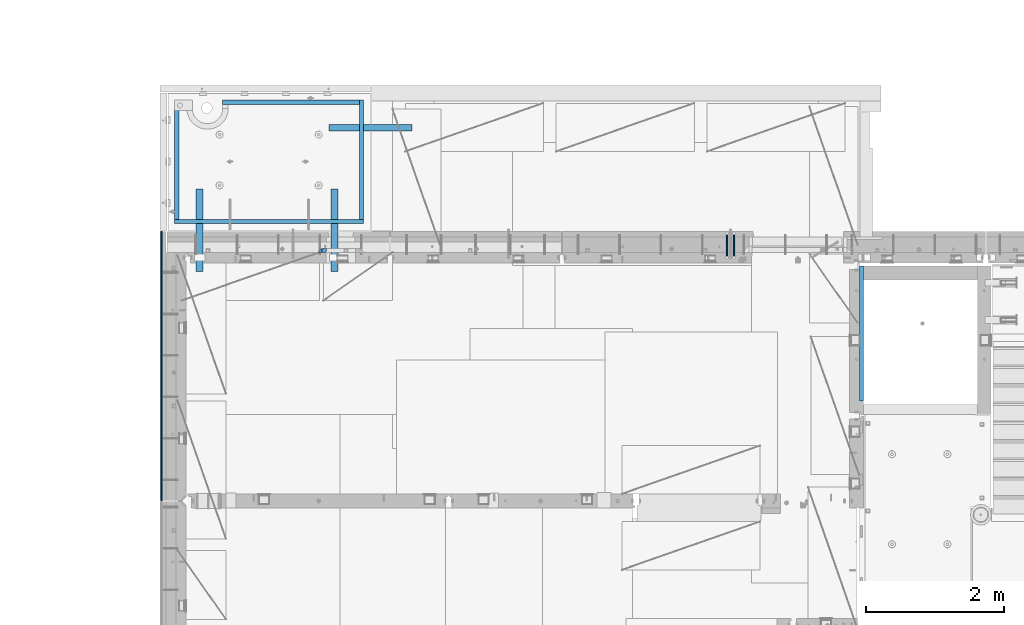
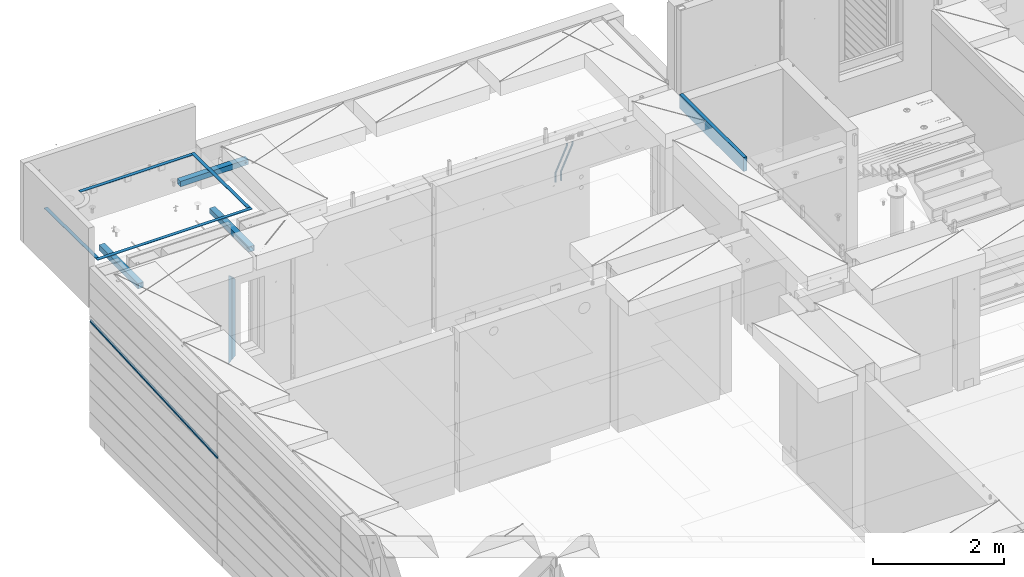
# One storey, part 102 of 325: 13 beams, 8 elements without a shape of their own.
"""IFC2X3 building model written with IfcOpenShell, lengths in millimetres."""

from ifc_helpers import new_model, si_unit, frame, origin_with_axes, place, context, subcontext, project, spatial, faceted_brep, material, type_object, element, aggregate, save


model = new_model("IFC2X3")

# Units and contexts
model_context = context("Model", 3, precision=1e-05, world=origin_with_axes())
body_context = subcontext(model_context, "Body", "Model", "MODEL_VIEW")
ifc_project = project(units=[si_unit("LENGTHUNIT", "METRE", prefix="MILLI"), si_unit("AREAUNIT", "SQUARE_METRE"), si_unit("VOLUMEUNIT", "CUBIC_METRE"), si_unit("MASSUNIT", "GRAM", prefix="KILO"), si_unit("TIMEUNIT", "SECOND"), si_unit("PLANEANGLEUNIT", "RADIAN"), si_unit("SOLIDANGLEUNIT", "STERADIAN"), si_unit("THERMODYNAMICTEMPERATUREUNIT", "DEGREE_CELSIUS"), si_unit("LUMINOUSINTENSITYUNIT", "LUMEN")], contexts=[model_context])

# Site, building, storey
site_placement = place(None, origin_with_axes())
site = spatial("IfcSite", under=ifc_project, at=site_placement, CompositionType="ELEMENT")
building_placement = place(site_placement, origin_with_axes())
building = spatial("IfcBuilding", under=site, at=building_placement, CompositionType="ELEMENT")
storey_placement = place(building_placement, origin_with_axes())
storey = spatial("IfcBuildingStorey", under=building, at=storey_placement, Name="1", CompositionType="ELEMENT", Elevation=0.0)

# Assembly, beam
assembly_1_placement = place(storey_placement, origin_with_axes())
assembly_1 = element("IfcElementAssembly", 1, at=assembly_1_placement, inside=storey, AssemblyPlace="NOTDEFINED", PredefinedType="REINFORCEMENT_UNIT")
ifc_material_1 = material(Name="CONCRETE/C25/30")
beam_type_1 = type_object("IfcBeamType", Name="260X60", PredefinedType="NOTDEFINED")
beam_1_placement = place(assembly_1_placement, frame((17779.9999105288, 18424.9992663657, 84600.0), z_axis=(0.0, 0.0, 1.0), x_axis=(0.0, 1.0, 0.0)))
beam_1 = element("IfcBeam", 2, at=beam_1_placement, type_object=beam_type_1, material=ifc_material_1, ObjectType="260X60", context=body_context, shape_type="Brep", body=[
    faceted_brep([(0.0, 30.0, -130.0), (0.0, 30.0, 130.0), (1954.9989445891, 30.0, 130.0), (1954.9989445891, 30.0, -130.0), (0.0, -30.0, 130.0), (1954.9989445891, -30.0, 130.0), (0.0, -30.0, -130.0), (1954.9989445891, -30.0, -130.0)], [[[0, 1, 2, 3]], [[1, 4, 5, 2]], [[4, 6, 7, 5]], [[6, 0, 3, 7]], [[5, 7, 3, 2]], [[6, 4, 1, 0]]]),
])
aggregate(assembly_1, [beam_1])

assembly_2_placement = place(storey_placement, origin_with_axes())
assembly_2 = element("IfcElementAssembly", 3, at=assembly_2_placement, inside=storey, AssemblyPlace="NOTDEFINED", PredefinedType="REINFORCEMENT_UNIT")
ifc_material_2 = material(Name="TIMBER/T24")
beam_type_2 = type_object("IfcBeamType", PredefinedType="NOTDEFINED")
beam_2_placement = place(assembly_2_placement, frame((7642.5, 20883.779945659, 83740.0714198882), z_axis=(1.0, 0.0, 0.0), x_axis=(0.0, -0.998808676266891, -0.0487978300130376)))
beam_2 = element("IfcBeam", 4, at=beam_2_placement, type_object=beam_type_2, material=ifc_material_2, context=body_context, shape_type="Brep", body=[
    faceted_brep([(-6.20211649220437e-05, -25.1793446455267, -0.208622932433173), (-1.45519152283669e-11, -3.63797880709171e-12, -12.5), (3904.70170998569, -1.35032916092314, -12.5), (3904.70170998569, -25.0000000000146, -0.955337660966507), (0.0, 25.0, -12.5), (0.0, 25.0, 12.5), (3904.70170998569, 25.0, 12.5), (3904.70170998569, 25.0, -12.5), (0.0, -25.0, 12.5), (3904.70170998569, -25.0000000000146, 12.5)], [[[0, 1, 2, 3]], [[4, 5, 6, 7]], [[5, 8, 9, 6]], [[9, 8, 0, 3]], [[7, 6, 9, 3, 2]], [[4, 7, 2, 1]], [[8, 5, 4, 1, 0]]]),
])
aggregate(assembly_2, [beam_2])

# Assemblies, beams
assembly_3_placement = place(storey_placement, origin_with_axes())
assembly_3 = element("IfcElementAssembly", 5, at=assembly_3_placement, inside=storey, AssemblyPlace="NOTDEFINED", PredefinedType="REINFORCEMENT_UNIT")
assembly_4_placement = place(assembly_3_placement, origin_with_axes())
assembly_4 = element("IfcElementAssembly", 6, at=assembly_4_placement, AssemblyPlace="NOTDEFINED", PredefinedType="NOTDEFINED")
ifc_material_3 = material(Name="Undefined/350")
beam_type_3 = type_object("IfcBeamType", Name="100X100X5", PredefinedType="NOTDEFINED")
beam_3_placement = place(assembly_4_placement, frame((10069.9865573969, 22385.0401432011, 84555.0), z_axis=(0.0, 0.0, 1.0), x_axis=(0.999999999752625, -2.22429999942101e-05, 0.0)))
beam_3 = element("IfcBeam", 7, at=beam_3_placement, type_object=beam_type_3, material=ifc_material_3, ObjectType="100X100X5", context=body_context, shape_type="Brep", body=[
    faceted_brep([(1156.2510802317, 44.9999999999982, 10.8253175473074), (1156.25107855315, 50.0256005946221, 10.8253175473074), (1160.82639610046, 50.0256021227788, 6.25), (1160.82639777901, 44.9999999999982, 6.25), (1150.00108023171, 44.9999999999982, 12.5), (1150.00107855316, 50.0255985071226, 12.5), (1143.75108023171, 44.9999999999982, 10.8253175473074), (1143.75107855316, 50.0255964196231, 10.8253175473074), (1139.1757626844, 44.9999999999982, 6.25), (1139.17576100585, 50.0255948914664, 6.25), (1137.5010802317, 44.9999999999982, 0.0), (1137.50107855316, 50.0255943321226, 0.0), (1139.1757626844, 44.9999999999982, -6.25), (1139.17576100585, 50.0255948914664, -6.25), (1143.75108023171, 44.9999999999982, -10.8253175473074), (1143.75107855316, 50.0255964196231, -10.8253175473074), (1150.00108023171, 44.9999999999982, -12.5), (1150.00107855316, 50.0255985071226, -12.5), (1156.2510802317, 44.9999999999982, -10.8253175473074), (1156.25107855315, 50.0256005946221, -10.8253175473074), (1160.82639777901, 44.9999999999982, -6.25), (1160.82639610046, 50.0256021227788, -6.25), (1162.50108023171, 44.9999999999982, 0.0), (1162.50107855316, 50.0256026821226, 0.0), (1156.25111195316, -49.9743994042774, 10.8253175473074), (1156.25111029171, -44.9999999999991, 10.8253175473074), (1160.82642783901, -44.9999999999991, 6.25), (1160.82642950046, -49.9743978761207, 6.25), (1150.00111195316, -49.9744014917787, 12.5), (1150.00111029171, -44.9999999999991, 12.5), (1143.75111195316, -49.9744035792783, 10.8253175473074), (1143.75111029171, -44.9999999999991, 10.8253175473074), (1139.17579440585, -49.9744051074349, 6.25), (1139.1757927444, -44.9999999999991, 6.25), (1137.50111195316, -49.9744056667778, 0.0), (1137.50111029171, -44.9999999999991, 0.0), (1139.17579440585, -49.9744051074349, -6.25), (1139.1757927444, -44.9999999999991, -6.25), (1143.75111195316, -49.9744035792783, -10.8253175473074), (1143.75111029171, -44.9999999999991, -10.8253175473074), (1150.00111195316, -49.9744014917787, -12.5), (1150.00111029171, -44.9999999999991, -12.5), (1156.25111195316, -49.9743994042774, -10.8253175473074), (1156.25111029171, -44.9999999999991, -10.8253175473074), (1160.82642950046, -49.9743978761207, -6.25), (1160.82642783901, -44.9999999999991, -6.25), (1162.50111195316, -49.9743973167779, 0.0), (1162.50111029171, -44.9999999999991, 0.0), (1.81898940354586e-12, -50.0000000000009, -50.0), (1.81898940354586e-12, 49.9999999999991, -50.0), (1200.00449189278, 49.9999999999982, -50.0), (1200.00449189278, -50.0000000000009, -50.0), (1.81898940354586e-12, 49.9999999999991, 50.0), (1.81898940354586e-12, -50.0000000000009, 50.0), (1200.00449189278, -50.0000000000009, 50.0), (1200.00449189278, 49.9999999999982, 50.0), (0.0, 44.9999999999991, 45.0), (1.81898940354586e-12, -45.0000000000009, 45.0), (1.81898940354586e-12, -45.0000000000009, -45.0), (0.0, 44.9999999999991, -45.0), (1200.00449189278, 44.9999999999982, -45.0), (1200.00449189278, 44.9999999999982, 45.0), (1200.00449189278, -45.0000000000009, 45.0), (1200.00449189278, -45.0000000000009, -45.0)], [[[0, 1, 2, 3]], [[4, 5, 1, 0]], [[6, 7, 5, 4]], [[8, 9, 7, 6]], [[10, 11, 9, 8]], [[12, 13, 11, 10]], [[14, 15, 13, 12]], [[16, 17, 15, 14]], [[18, 19, 17, 16]], [[20, 21, 19, 18]], [[22, 23, 21, 20]], [[3, 2, 23, 22]], [[24, 25, 26, 27]], [[28, 29, 25, 24]], [[30, 31, 29, 28]], [[32, 33, 31, 30]], [[34, 35, 33, 32]], [[36, 37, 35, 34]], [[38, 39, 37, 36]], [[40, 41, 39, 38]], [[42, 43, 41, 40]], [[44, 45, 43, 42]], [[46, 47, 45, 44]], [[27, 26, 47, 46]], [[48, 49, 50, 51]], [[52, 53, 54, 55]], [[49, 52, 55, 50], [1, 5, 7, 9, 11, 13, 15, 17, 19, 21, 23, 2]], [[48, 53, 52, 49], [56, 57, 58, 59]], [[56, 59, 60, 61], [18, 16, 14, 12, 10, 8, 6, 4, 0, 3, 22, 20]], [[57, 56, 61, 62]], [[58, 57, 62, 63], [25, 29, 31, 33, 35, 37, 39, 41, 43, 45, 47, 26]], [[59, 58, 63, 60]], [[54, 51, 50, 55], [62, 61, 60, 63]], [[53, 48, 51, 54], [42, 40, 38, 36, 34, 32, 30, 28, 24, 27, 46, 44]]]),
])
aggregate(assembly_4, [beam_3])
assembly_5_placement = place(assembly_3_placement, origin_with_axes())
assembly_5 = element("IfcElementAssembly", 8, at=assembly_5_placement, AssemblyPlace="NOTDEFINED", PredefinedType="NOTDEFINED")
beam_4_placement = place(assembly_5_placement, frame((10150.0001432011, 21500.0034426031, 84555.0), z_axis=(0.0, 0.0, 1.0), x_axis=(-2.2242999997242e-05, -0.999999999752625, 0.0)))
beam_4 = element("IfcBeam", 9, at=beam_4_placement, type_object=beam_type_3, material=ifc_material_3, ObjectType="100X100X5", context=body_context, shape_type="Brep", body=[
    faceted_brep([(1143.75108023171, 44.9999999999982, -10.8253175473074), (1143.75107855316, 50.0255964196231, -10.8253175473074), (1139.17576100585, 50.0255948914664, -6.25), (1139.1757626844, 44.9999999999982, -6.25), (1150.00108023171, 44.9999999999982, -12.5), (1150.00107855316, 50.0255985071226, -12.5), (1156.2510802317, 44.9999999999982, -10.8253175473074), (1156.25107855315, 50.0256005946221, -10.8253175473074), (1160.82639777901, 44.9999999999982, -6.25), (1160.82639610046, 50.0256021227788, -6.25), (1162.50108023171, 44.9999999999982, 0.0), (1162.50107855316, 50.0256026821226, 0.0), (1160.82639777901, 44.9999999999982, 6.25), (1160.82639610046, 50.0256021227788, 6.25), (1156.2510802317, 44.9999999999982, 10.8253175473074), (1156.25107855315, 50.0256005946221, 10.8253175473074), (1150.00108023171, 44.9999999999982, 12.5), (1150.00107855316, 50.0255985071226, 12.5), (1143.75108023171, 44.9999999999982, 10.8253175473074), (1143.75107855316, 50.0255964196231, 10.8253175473074), (1139.1757626844, 44.9999999999982, 6.25), (1139.17576100585, 50.0255948914664, 6.25), (1137.5010802317, 44.9999999999982, 0.0), (1137.50107855316, 50.0255943321226, 0.0), (1143.75111195316, -49.9744035792783, -10.8253175473074), (1143.75111029171, -44.9999999999991, -10.8253175473074), (1139.1757927444, -44.9999999999991, -6.25), (1139.17579440585, -49.9744051074349, -6.25), (1150.00111195316, -49.9744014917787, -12.5), (1150.00111029171, -44.9999999999991, -12.5), (1156.25111195316, -49.9743994042774, -10.8253175473074), (1156.25111029171, -44.9999999999991, -10.8253175473074), (1160.82642950046, -49.9743978761207, -6.25), (1160.82642783901, -44.9999999999991, -6.25), (1162.50111195316, -49.9743973167779, 0.0), (1162.50111029171, -44.9999999999991, 0.0), (1160.82642950046, -49.9743978761207, 6.25), (1160.82642783901, -44.9999999999991, 6.25), (1156.25111195316, -49.9743994042774, 10.8253175473074), (1156.25111029171, -44.9999999999991, 10.8253175473074), (1150.00111195316, -49.9744014917787, 12.5), (1150.00111029171, -44.9999999999991, 12.5), (1143.75111195316, -49.9744035792783, 10.8253175473074), (1143.75111029171, -44.9999999999991, 10.8253175473074), (1139.17579440585, -49.9744051074349, 6.25), (1139.1757927444, -44.9999999999991, 6.25), (1137.50111195316, -49.9744056667778, 0.0), (1137.50111029171, -44.9999999999991, 0.0), (1.81898940354586e-12, -50.0000000000009, -50.0), (1.81898940354586e-12, 49.9999999999991, -50.0), (1200.00449189278, 49.9999999999982, -50.0), (1200.00449189278, -50.0000000000009, -50.0), (1.81898940354586e-12, 49.9999999999991, 50.0), (1.81898940354586e-12, -50.0000000000009, 50.0), (1200.00449189278, -50.0000000000009, 50.0), (1200.00449189278, 49.9999999999982, 50.0), (0.0, 44.9999999999991, 45.0), (1.81898940354586e-12, -45.0000000000009, 45.0), (1.81898940354586e-12, -45.0000000000009, -45.0), (0.0, 44.9999999999991, -45.0), (1200.00449189278, 44.9999999999982, -45.0), (1200.00449189278, 44.9999999999982, 45.0), (1200.00449189278, -45.0000000000009, 45.0), (1200.00449189278, -45.0000000000009, -45.0)], [[[0, 1, 2, 3]], [[4, 5, 1, 0]], [[6, 7, 5, 4]], [[8, 9, 7, 6]], [[10, 11, 9, 8]], [[12, 13, 11, 10]], [[14, 15, 13, 12]], [[16, 17, 15, 14]], [[18, 19, 17, 16]], [[20, 21, 19, 18]], [[22, 23, 21, 20]], [[3, 2, 23, 22]], [[24, 25, 26, 27]], [[28, 29, 25, 24]], [[30, 31, 29, 28]], [[32, 33, 31, 30]], [[34, 35, 33, 32]], [[36, 37, 35, 34]], [[38, 39, 37, 36]], [[40, 41, 39, 38]], [[42, 43, 41, 40]], [[44, 45, 43, 42]], [[46, 47, 45, 44]], [[27, 26, 47, 46]], [[48, 49, 50, 51]], [[52, 53, 54, 55]], [[49, 52, 55, 50], [15, 17, 19, 21, 23, 2, 1, 5, 7, 9, 11, 13]], [[48, 53, 52, 49], [56, 57, 58, 59]], [[56, 59, 60, 61], [6, 4, 0, 3, 22, 20, 18, 16, 14, 12, 10, 8]], [[57, 56, 61, 62]], [[58, 57, 62, 63], [39, 41, 43, 45, 47, 26, 25, 29, 31, 33, 35, 37]], [[59, 58, 63, 60]], [[54, 51, 50, 55], [62, 61, 60, 63]], [[53, 48, 51, 54], [30, 28, 24, 27, 46, 44, 42, 40, 38, 36, 34, 32]]]),
])
aggregate(assembly_5, [beam_4])
assembly_6_placement = place(assembly_3_placement, origin_with_axes())
assembly_6 = element("IfcElementAssembly", 10, at=assembly_6_placement, AssemblyPlace="NOTDEFINED", PredefinedType="NOTDEFINED")
beam_5_placement = place(assembly_6_placement, frame((8195.00014320107, 21500.0034426031, 84555.0), z_axis=(0.0, 0.0, 1.0), x_axis=(-2.2242999997242e-05, -0.999999999752625, 0.0)))
beam_5 = element("IfcBeam", 11, at=beam_5_placement, type_object=beam_type_3, material=ifc_material_3, ObjectType="100X100X5", context=body_context, shape_type="Brep", body=[
    faceted_brep([(1143.75108023171, 44.9999999999982, -10.8253175473074), (1143.75107855316, 50.0255964196231, -10.8253175473074), (1139.17576100585, 50.0255948914664, -6.25), (1139.1757626844, 44.9999999999982, -6.25), (1150.00108023171, 44.9999999999982, -12.5), (1150.00107855316, 50.0255985071226, -12.5), (1156.2510802317, 44.9999999999982, -10.8253175473074), (1156.25107855315, 50.0256005946221, -10.8253175473074), (1160.82639777901, 44.9999999999982, -6.25), (1160.82639610046, 50.0256021227788, -6.25), (1162.50108023171, 44.9999999999982, 0.0), (1162.50107855316, 50.0256026821226, 0.0), (1160.82639777901, 44.9999999999982, 6.25), (1160.82639610046, 50.0256021227788, 6.25), (1156.2510802317, 44.9999999999982, 10.8253175473074), (1156.25107855315, 50.0256005946221, 10.8253175473074), (1150.00108023171, 44.9999999999982, 12.5), (1150.00107855316, 50.0255985071226, 12.5), (1143.75108023171, 44.9999999999982, 10.8253175473074), (1143.75107855316, 50.0255964196231, 10.8253175473074), (1139.1757626844, 44.9999999999982, 6.25), (1139.17576100585, 50.0255948914664, 6.25), (1137.5010802317, 44.9999999999982, 0.0), (1137.50107855316, 50.0255943321226, 0.0), (1143.75111195316, -49.9744035792783, -10.8253175473074), (1143.75111029171, -44.9999999999991, -10.8253175473074), (1139.1757927444, -44.9999999999991, -6.25), (1139.17579440585, -49.9744051074349, -6.25), (1150.00111195316, -49.9744014917787, -12.5), (1150.00111029171, -44.9999999999991, -12.5), (1156.25111195316, -49.9743994042774, -10.8253175473074), (1156.25111029171, -44.9999999999991, -10.8253175473074), (1160.82642950046, -49.9743978761207, -6.25), (1160.82642783901, -44.9999999999991, -6.25), (1162.50111195316, -49.9743973167779, 0.0), (1162.50111029171, -44.9999999999991, 0.0), (1160.82642950046, -49.9743978761207, 6.25), (1160.82642783901, -44.9999999999991, 6.25), (1156.25111195316, -49.9743994042774, 10.8253175473074), (1156.25111029171, -44.9999999999991, 10.8253175473074), (1150.00111195316, -49.9744014917787, 12.5), (1150.00111029171, -44.9999999999991, 12.5), (1143.75111195316, -49.9744035792783, 10.8253175473074), (1143.75111029171, -44.9999999999991, 10.8253175473074), (1139.17579440585, -49.9744051074349, 6.25), (1139.1757927444, -44.9999999999991, 6.25), (1137.50111195316, -49.9744056667778, 0.0), (1137.50111029171, -44.9999999999991, 0.0), (1.81898940354586e-12, -50.0000000000009, -50.0), (1.81898940354586e-12, 49.9999999999991, -50.0), (1200.00449189278, 49.9999999999982, -50.0), (1200.00449189278, -50.0000000000009, -50.0), (1.81898940354586e-12, 49.9999999999991, 50.0), (1.81898940354586e-12, -50.0000000000009, 50.0), (1200.00449189278, -50.0000000000009, 50.0), (1200.00449189278, 49.9999999999982, 50.0), (0.0, 44.9999999999991, 45.0), (1.81898940354586e-12, -45.0000000000009, 45.0), (1.81898940354586e-12, -45.0000000000009, -45.0), (0.0, 44.9999999999991, -45.0), (1200.00449189278, 44.9999999999982, -45.0), (1200.00449189278, 44.9999999999982, 45.0), (1200.00449189278, -45.0000000000009, 45.0), (1200.00449189278, -45.0000000000009, -45.0)], [[[0, 1, 2, 3]], [[4, 5, 1, 0]], [[6, 7, 5, 4]], [[8, 9, 7, 6]], [[10, 11, 9, 8]], [[12, 13, 11, 10]], [[14, 15, 13, 12]], [[16, 17, 15, 14]], [[18, 19, 17, 16]], [[20, 21, 19, 18]], [[22, 23, 21, 20]], [[3, 2, 23, 22]], [[24, 25, 26, 27]], [[28, 29, 25, 24]], [[30, 31, 29, 28]], [[32, 33, 31, 30]], [[34, 35, 33, 32]], [[36, 37, 35, 34]], [[38, 39, 37, 36]], [[40, 41, 39, 38]], [[42, 43, 41, 40]], [[44, 45, 43, 42]], [[46, 47, 45, 44]], [[27, 26, 47, 46]], [[48, 49, 50, 51]], [[52, 53, 54, 55]], [[49, 52, 55, 50], [15, 17, 19, 21, 23, 2, 1, 5, 7, 9, 11, 13]], [[48, 53, 52, 49], [56, 57, 58, 59]], [[56, 59, 60, 61], [6, 4, 0, 3, 22, 20, 18, 16, 14, 12, 10, 8]], [[57, 56, 61, 62]], [[58, 57, 62, 63], [39, 41, 43, 45, 47, 26, 25, 29, 31, 33, 35, 37]], [[59, 58, 63, 60]], [[54, 51, 50, 55], [62, 61, 60, 63]], [[53, 48, 51, 54], [30, 28, 24, 27, 46, 44, 42, 40, 38, 36, 34, 32]]]),
])
aggregate(assembly_6, [beam_5])
ifc_material_4 = material(Name="CONCRETE/Concrete_Undefined")
beam_type_4 = type_object("IfcBeamType", PredefinedType="NOTDEFINED")
beam_6_placement = place(assembly_3_placement, frame((8529.99466999203, 22755.2837502302, 84702.830444231), z_axis=(-8.94119999996021e-05, 2.00000067707701e-09, 0.999999996002747), x_axis=(0.999999995749149, -2.25209999937896e-05, 8.94119999812374e-05)))
beam_6 = element("IfcBeam", 12, at=beam_6_placement, type_object=beam_type_4, material=ifc_material_4, context=body_context, shape_type="Brep", body=[
    faceted_brep([(2.5465851649642e-11, 29.9999999999982, -4.99999999998545), (-2.91038304567337e-11, 29.9999999999982, 5.0), (1980.00575712919, 30.0, 5.0), (1980.00575712919, 30.0, -5.0), (-2.5465851649642e-11, -30.0000000000018, 5.0), (1980.00575712919, -30.0, 5.0), (2.72848410531878e-11, -30.0000000000018, -4.99999999998545), (1980.00575712919, -30.0, -5.00000000001455)], [[[0, 1, 2, 3]], [[1, 4, 5, 2]], [[4, 6, 7, 5]], [[6, 0, 3, 7]], [[5, 7, 3, 2]], [[6, 4, 1, 0]]]),
])
beam_7_placement = place(assembly_3_placement, frame((10540.0586106742, 21059.9845873458, 84723.6637899649), z_axis=(-4.06999999693443e-07, 0.0121707750045615, 0.999925933374879), x_axis=(-3.34759999933477e-05, 0.999925932814682, -0.0121707749977451)))
beam_7 = element("IfcBeam", 13, at=beam_7_placement, type_object=beam_type_4, material=ifc_material_4, context=body_context, shape_type="Brep", body=[
    faceted_brep([(2.5465851649642e-11, 29.9999999999982, -4.99999999998545), (-2.91038304567337e-11, 29.9999999999982, 5.0), (1725.44357525616, 30.0000000000036, 5.00000000001455), (1725.4435752563, 30.0, -4.9999999999709), (-2.5465851649642e-11, -30.0000000000018, 5.0), (1725.44357525616, -29.9999999999964, 5.0000000000291), (2.72848410531878e-11, -30.0000000000018, -4.99999999998545), (1725.4435752563, -30.0, -4.99999999998545)], [[[0, 1, 2, 3]], [[1, 4, 5, 2]], [[4, 6, 7, 5]], [[6, 0, 3, 7]], [[5, 7, 3, 2]], [[6, 4, 1, 0]]]),
])
beam_8_placement = place(assembly_3_placement, frame((7864.99860986461, 21059.9382586606, 84723.2791563128), z_axis=(9.00000032044727e-09, 0.0117810320027604, 0.999930601234381), x_axis=(7.88999999912068e-07, 0.999930601234069, -0.011781032002762)))
beam_8 = element("IfcBeam", 14, at=beam_8_placement, type_object=beam_type_4, material=ifc_material_4, context=body_context, shape_type="Brep", body=[
    faceted_brep([(2.5465851649642e-11, 29.9999999999982, -4.99999999998545), (-2.91038304567337e-11, 29.9999999999982, 5.0), (1580.11368192099, 30.0000000000018, 5.0), (1580.11368192098, 30.0000000000009, -5.00000000001455), (-2.5465851649642e-11, -30.0000000000018, 5.0), (1580.11368192098, -29.9999999999991, 5.0), (2.72848410531878e-11, -30.0000000000018, -4.99999999998545), (1580.11368192098, -30.0, -5.0)], [[[0, 1, 2, 3]], [[1, 4, 5, 2]], [[4, 6, 7, 5]], [[6, 0, 3, 7]], [[5, 7, 3, 2]], [[6, 4, 1, 0]]]),
])
beam_9_placement = place(assembly_3_placement, frame((7834.99819277187, 21029.998155674, 84724.2788443216), z_axis=(-0.000140627000015522, 4.00000135459113e-09, 0.999999990112023), x_axis=(0.999999989763253, -2.64109999939869e-05, 0.000140626999967189)))
beam_9 = element("IfcBeam", 15, at=beam_9_placement, type_object=beam_type_4, material=ifc_material_4, context=body_context, shape_type="Brep", body=[
    faceted_brep([(2.5465851649642e-11, 29.9999999999982, -4.99999999998545), (-2.91038304567337e-11, 29.9999999999982, 5.0), (2735.00002544224, 30.0, 5.0), (2735.00002544224, 30.0, -5.0), (-2.5465851649642e-11, -30.0000000000018, 5.0), (2735.00002544224, -29.9999999999964, 5.0), (2.72848410531878e-11, -30.0000000000018, -4.99999999998545), (2735.00002544224, -29.9999999999964, -5.0)], [[[0, 1, 2, 3]], [[1, 4, 5, 2]], [[4, 6, 7, 5]], [[6, 0, 3, 7]], [[5, 7, 3, 2]], [[6, 4, 1, 0]]]),
])
aggregate(assembly_3, [assembly_4, assembly_5, assembly_6, beam_6, beam_7, beam_8, beam_9])

# Assembly, beams
assembly_7_placement = place(storey_placement, origin_with_axes())
assembly_7 = element("IfcElementAssembly", 16, at=assembly_7_placement, inside=storey, AssemblyPlace="NOTDEFINED", PredefinedType="REINFORCEMENT_UNIT")
beam_type_5 = type_object("IfcBeamType", PredefinedType="NOTDEFINED")
beam_10_placement = place(assembly_7_placement, frame((9934.99976962805, 20609.9951872276, 83975.0), z_axis=(1.0, 0.0, 0.0), x_axis=(0.0, 0.0, -1.0)))
beam_10 = element("IfcBeam", 17, at=beam_10_placement, type_object=beam_type_5, material=ifc_material_1, context=body_context, shape_type="Brep", body=[
    faceted_brep([(60.0000000000073, 30.0, 30.0), (0.0, -30.0, -30.0), (60.0000000000073, -30.0, 30.0), (1655.0, -30.0, -30.0), (1595.00000000001, -30.0, 30.0), (1595.00000000001, 30.0, 30.0)], [[[0, 1, 2]], [[3, 4, 2, 1]], [[4, 3, 5]], [[4, 5, 0, 2]], [[5, 3, 1, 0]]]),
])
beam_type_6 = type_object("IfcBeamType", PredefinedType="NOTDEFINED")
beam_11_placement = place(assembly_7_placement, frame((9999.99976962805, 20609.9951872276, 83915.0), z_axis=(1.0, 0.0, 0.0), x_axis=(0.0, 0.0, -1.0)))
beam_11 = element("IfcBeam", 18, at=beam_11_placement, type_object=beam_type_6, material=ifc_material_1, context=body_context, shape_type="Brep", body=[
    faceted_brep([(0.0, -30.0, -35.0), (54.9034748914273, -30.0, 29.0540540540533), (56.2934362811066, 30.0, 30.6756756756768), (0.0, 30.0, -35.0), (1478.70656371891, 30.0, 30.6756756756749), (1535.0, 30.0, -35.0), (1535.0, -30.0, -35.0), (1480.09652510857, -30.0, 29.0540540540533)], [[[0, 1, 2, 3]], [[3, 2, 4, 5]], [[5, 6, 0, 3]], [[1, 0, 6, 7]], [[2, 1, 7, 4]], [[6, 5, 4, 7]]]),
])
aggregate(assembly_7, [beam_10, beam_11])

assembly_8_placement = place(storey_placement, origin_with_axes())
assembly_8 = element("IfcElementAssembly", 19, at=assembly_8_placement, inside=storey, AssemblyPlace="NOTDEFINED", PredefinedType="REINFORCEMENT_UNIT")
ifc_material_5 = material()
beam_type_7 = type_object("IfcBeamType", Name="D32", PredefinedType="NOTDEFINED")
beam_12_placement = place(assembly_8_placement, frame((15835.4068420371, 20505.0048127724, 84407.4962872484), z_axis=(-1.61699999983392e-06, 0.999209506961324, 0.0397537569984599), x_axis=(-6.39999925638304e-08, 0.039753756998479, -0.99920950696263)))
beam_12 = element("IfcBeam", 20, at=beam_12_placement, type_object=beam_type_7, material=ifc_material_5, Name="JM32", ObjectType="D32", context=body_context, shape_type="Brep", body=[
    faceted_brep([(0.0, -16.0, 0.0), (0.0, -13.8564064605507, -8.0), (36.8537758823077, -13.8564064484963, -7.9999999830834), (36.8537758791499, -15.9999999877982, 6.10623828833923e-07), (0.0, -8.0, -13.8564064605507), (36.8537758830789, -7.99999998794374, -13.8564064436323), (0.0, 0.0, -16.0), (36.8537758814491, 1.20544427772984e-08, -15.9999999830834), (0.0, 8.0, -13.8564064605507), (36.8537758778548, 8.00000001205444, -13.8564064436323), (0.0, 13.8564064605507, -8.0), (36.8537758732418, 13.856406472607, -7.9999999830834), (0.0, 16.0, 0.0), (36.8537758688617, 16.0000000120563, 1.69166014529765e-08), (0.0, 13.8564064605507, 8.0), (36.8537758658931, 13.856406472607, 8.00000001692024), (0.0, 8.0, 13.8564064605507), (36.8537758651219, 8.00000001205444, 13.8564064774691), (0.0, 0.0, 16.0), (36.8537758667662, 1.20544427772984e-08, 16.0000000169202), (0.0, -8.0, 13.8564064605507), (36.8537758703606, -7.99999998794556, 13.8564064774655), (0.0, -13.8564064605507, 8.0), (36.853775874959, -13.8564064484945, 8.00000001692024), (47.9907490845508, -13.8564107655602, -5.6898362473512), (44.808752656143, -16.0000028597933, 1.65011575700555), (50.320135344984, -8.00000536309381, -11.0630539680824), (51.1727540337743, -5.75039484829176e-06, -13.0297875114738), (50.3201466617174, 7.999994636868, -11.0630522128777), (47.9907686857041, 13.8564021554794, -5.68983320727057), (44.8087750531267, 15.9999971402722, 1.65011981200951), (41.626778388294, 13.8564050461846, 8.99007236098987), (39.2973921278317, 7.99999964371455, 14.3632900817174), (38.444773439187, 3.10155883198604e-08, 16.330023625138), (39.2973808112729, -8.00000035624726, 14.3632883265927), (41.6267587873735, -13.856407874855, 8.99006932098564), (774.025219208037, -13.8569585138612, 309.05853143011), (770.843222342926, -16.0005509033763, 316.39848443908), (776.354605382148, -8.00055289424745, 303.68531390866), (777.207223952908, -0.0005532020550163, 301.718580637447), (776.354616462791, 7.99944710574709, 303.685316208226), (774.025238400267, 13.855854407233, 309.058535413071), (770.843244736054, 15.999449095425, 316.398488505296), (767.661248102799, 13.8558567047166, 323.738440981349), (765.331861928687, 7.99945108510474, 329.111658502799), (764.479243357957, -0.000548607089513098, 331.078391774012), (765.331850848044, -8.00054891489162, 329.111656203233), (767.661228910554, -13.8569562163757, 323.738436998385), (779.188076052422, -13.8569608533471, 310.042269923688), (779.447979545323, -16.000554326165, 318.038046381829), (778.997813775641, -8.00055444243844, 304.188954839177), (778.928173355278, -0.00055446062287956, 302.046492758986), (778.997814885734, 7.99944555752336, 304.188954667366), (779.188077975123, 13.8558520676997, 310.042269626101), (779.447981782389, 15.9994456749373, 318.038046618982), (779.707885292184, 13.8558522032981, 326.03382365789), (779.898147568994, 7.99944579238036, 331.887138742415), (779.967787989357, -0.000554189437025343, 334.029600822581), (779.898146458901, -8.00055420758326, 331.887138914244), (779.707883369469, -13.8569607177542, 326.033823955488), (947.914738334759, -13.8569723325145, 304.557789703631), (948.17464184227, -16.0005660918596, 312.553566665509), (947.724476064657, -8.00056571099049, 298.704474829625), (947.654835653593, -0.000565652067962219, 296.562013037019), (947.724477193493, 7.99943428900951, 298.704475232957), (947.914740289954, 13.8558405885869, 304.557790402225), (948.174644099941, 15.9994339081404, 312.553567472165), (948.434547607438, 13.8558401487935, 320.549344434046), (948.624809877554, 7.9994335272695, 326.402659308053), (948.694450288604, -0.000566531653021229, 328.545121100662), (948.624808748718, -8.0005664727305, 326.402658904721), (948.434545652271, -13.8569727723079, 320.54934373546)], [[[0, 1, 2, 3]], [[1, 4, 5, 2]], [[4, 6, 7, 5]], [[6, 8, 9, 7]], [[8, 10, 11, 9]], [[10, 12, 13, 11]], [[12, 14, 15, 13]], [[14, 16, 17, 15]], [[16, 18, 19, 17]], [[18, 20, 21, 19]], [[20, 22, 23, 21]], [[22, 0, 3, 23]], [[22, 20, 18, 16, 14, 12, 10, 8, 6, 4, 1, 0]], [[3, 2, 24, 25]], [[2, 5, 26, 24]], [[5, 7, 27, 26]], [[7, 9, 28, 27]], [[9, 11, 29, 28]], [[11, 13, 30, 29]], [[13, 15, 31, 30]], [[15, 17, 32, 31]], [[17, 19, 33, 32]], [[19, 21, 34, 33]], [[21, 23, 35, 34]], [[23, 3, 25, 35]], [[25, 24, 36, 37]], [[24, 26, 38, 36]], [[26, 27, 39, 38]], [[27, 28, 40, 39]], [[28, 29, 41, 40]], [[29, 30, 42, 41]], [[30, 31, 43, 42]], [[31, 32, 44, 43]], [[32, 33, 45, 44]], [[33, 34, 46, 45]], [[34, 35, 47, 46]], [[35, 25, 37, 47]], [[37, 36, 48, 49]], [[36, 38, 50, 48]], [[38, 39, 51, 50]], [[39, 40, 52, 51]], [[40, 41, 53, 52]], [[41, 42, 54, 53]], [[42, 43, 55, 54]], [[43, 44, 56, 55]], [[44, 45, 57, 56]], [[45, 46, 58, 57]], [[46, 47, 59, 58]], [[47, 37, 49, 59]], [[49, 48, 60, 61]], [[48, 50, 62, 60]], [[50, 51, 63, 62]], [[51, 52, 64, 63]], [[52, 53, 65, 64]], [[53, 54, 66, 65]], [[54, 55, 67, 66]], [[55, 56, 68, 67]], [[56, 57, 69, 68]], [[57, 58, 70, 69]], [[58, 59, 71, 70]], [[59, 49, 61, 71]], [[62, 63, 64, 65, 66, 67, 68, 69, 70, 71, 61, 60]]]),
])
beam_13_placement = place(assembly_8_placement, frame((15935.4068420371, 20505.0048127724, 84407.4962872484), z_axis=(-1.61699999983392e-06, 0.999209506961324, 0.0397537569984599), x_axis=(-6.39999925638304e-08, 0.039753756998479, -0.99920950696263)))
beam_13 = element("IfcBeam", 21, at=beam_13_placement, type_object=beam_type_7, material=ifc_material_5, Name="JM32", ObjectType="D32", context=body_context, shape_type="Brep", body=[
    faceted_brep([(0.0, -16.0, 0.0), (0.0, -13.8564064605507, -8.0), (36.8537758823077, -13.8564064484963, -7.9999999830834), (36.8537758791499, -15.9999999877982, 6.10623828833923e-07), (0.0, -8.0, -13.8564064605507), (36.8537758830789, -7.99999998794374, -13.8564064436323), (0.0, 0.0, -16.0), (36.8537758814491, 1.20544427772984e-08, -15.9999999830834), (0.0, 8.0, -13.8564064605507), (36.8537758778548, 8.00000001205444, -13.8564064436323), (0.0, 13.8564064605507, -8.0), (36.8537758732418, 13.856406472607, -7.9999999830834), (0.0, 16.0, 0.0), (36.8537758688617, 16.0000000120563, 1.69166014529765e-08), (0.0, 13.8564064605507, 8.0), (36.8537758658931, 13.856406472607, 8.00000001692024), (0.0, 8.0, 13.8564064605507), (36.8537758651219, 8.00000001205444, 13.8564064774691), (0.0, 0.0, 16.0), (36.8537758667662, 1.20544427772984e-08, 16.0000000169202), (0.0, -8.0, 13.8564064605507), (36.8537758703606, -7.99999998794556, 13.8564064774655), (0.0, -13.8564064605507, 8.0), (36.853775874959, -13.8564064484945, 8.00000001692024), (47.9907490845508, -13.8564107655602, -5.6898362473512), (44.808752656143, -16.0000028597933, 1.65011575700555), (50.320135344984, -8.00000536309381, -11.0630539680824), (51.1727540337743, -5.75039484829176e-06, -13.0297875114738), (50.3201466617174, 7.999994636868, -11.0630522128777), (47.9907686857041, 13.8564021554794, -5.68983320727057), (44.8087750531267, 15.9999971402722, 1.65011981200951), (41.626778388294, 13.8564050461846, 8.99007236098987), (39.2973921278317, 7.99999964371455, 14.3632900817174), (38.444773439187, 3.10155883198604e-08, 16.330023625138), (39.2973808112729, -8.00000035624726, 14.3632883265927), (41.6267587873735, -13.856407874855, 8.99006932098564), (774.025219208037, -13.8569585138612, 309.05853143011), (770.843222342926, -16.0005509033763, 316.39848443908), (776.354605382148, -8.00055289424745, 303.68531390866), (777.207223952908, -0.0005532020550163, 301.718580637447), (776.354616462791, 7.99944710574709, 303.685316208226), (774.025238400267, 13.855854407233, 309.058535413071), (770.843244736054, 15.999449095425, 316.398488505296), (767.661248102799, 13.8558567047166, 323.738440981349), (765.331861928687, 7.99945108510474, 329.111658502799), (764.479243357957, -0.000548607089513098, 331.078391774012), (765.331850848044, -8.00054891489162, 329.111656203233), (767.661228910554, -13.8569562163757, 323.738436998385), (779.188076052422, -13.8569608533471, 310.042269923688), (779.447979545323, -16.000554326165, 318.038046381829), (778.997813775641, -8.00055444243844, 304.188954839177), (778.928173355278, -0.00055446062287956, 302.046492758986), (778.997814885734, 7.99944555752336, 304.188954667366), (779.188077975123, 13.8558520676997, 310.042269626101), (779.447981782389, 15.9994456749373, 318.038046618982), (779.707885292184, 13.8558522032981, 326.03382365789), (779.898147568994, 7.99944579238036, 331.887138742415), (779.967787989357, -0.000554189437025343, 334.029600822581), (779.898146458901, -8.00055420758326, 331.887138914244), (779.707883369469, -13.8569607177542, 326.033823955488), (947.914738334759, -13.8569723325145, 304.557789703631), (948.17464184227, -16.0005660918596, 312.553566665509), (947.724476064657, -8.00056571099049, 298.704474829625), (947.654835653593, -0.000565652067962219, 296.562013037019), (947.724477193493, 7.99943428900951, 298.704475232957), (947.914740289954, 13.8558405885869, 304.557790402225), (948.174644099941, 15.9994339081404, 312.553567472165), (948.434547607438, 13.8558401487935, 320.549344434046), (948.624809877554, 7.9994335272695, 326.402659308053), (948.694450288604, -0.000566531653021229, 328.545121100662), (948.624808748718, -8.0005664727305, 326.402658904721), (948.434545652271, -13.8569727723079, 320.54934373546)], [[[0, 1, 2, 3]], [[1, 4, 5, 2]], [[4, 6, 7, 5]], [[6, 8, 9, 7]], [[8, 10, 11, 9]], [[10, 12, 13, 11]], [[12, 14, 15, 13]], [[14, 16, 17, 15]], [[16, 18, 19, 17]], [[18, 20, 21, 19]], [[20, 22, 23, 21]], [[22, 0, 3, 23]], [[22, 20, 18, 16, 14, 12, 10, 8, 6, 4, 1, 0]], [[3, 2, 24, 25]], [[2, 5, 26, 24]], [[5, 7, 27, 26]], [[7, 9, 28, 27]], [[9, 11, 29, 28]], [[11, 13, 30, 29]], [[13, 15, 31, 30]], [[15, 17, 32, 31]], [[17, 19, 33, 32]], [[19, 21, 34, 33]], [[21, 23, 35, 34]], [[23, 3, 25, 35]], [[25, 24, 36, 37]], [[24, 26, 38, 36]], [[26, 27, 39, 38]], [[27, 28, 40, 39]], [[28, 29, 41, 40]], [[29, 30, 42, 41]], [[30, 31, 43, 42]], [[31, 32, 44, 43]], [[32, 33, 45, 44]], [[33, 34, 46, 45]], [[34, 35, 47, 46]], [[35, 25, 37, 47]], [[37, 36, 48, 49]], [[36, 38, 50, 48]], [[38, 39, 51, 50]], [[39, 40, 52, 51]], [[40, 41, 53, 52]], [[41, 42, 54, 53]], [[42, 43, 55, 54]], [[43, 44, 56, 55]], [[44, 45, 57, 56]], [[45, 46, 58, 57]], [[46, 47, 59, 58]], [[47, 37, 49, 59]], [[49, 48, 60, 61]], [[48, 50, 62, 60]], [[50, 51, 63, 62]], [[51, 52, 64, 63]], [[52, 53, 65, 64]], [[53, 54, 66, 65]], [[54, 55, 67, 66]], [[55, 56, 68, 67]], [[56, 57, 69, 68]], [[57, 58, 70, 69]], [[58, 59, 71, 70]], [[59, 49, 61, 71]], [[62, 63, 64, 65, 66, 67, 68, 69, 70, 71, 61, 60]]]),
])
aggregate(assembly_8, [beam_12, beam_13])

save(model, "model.ifc")
